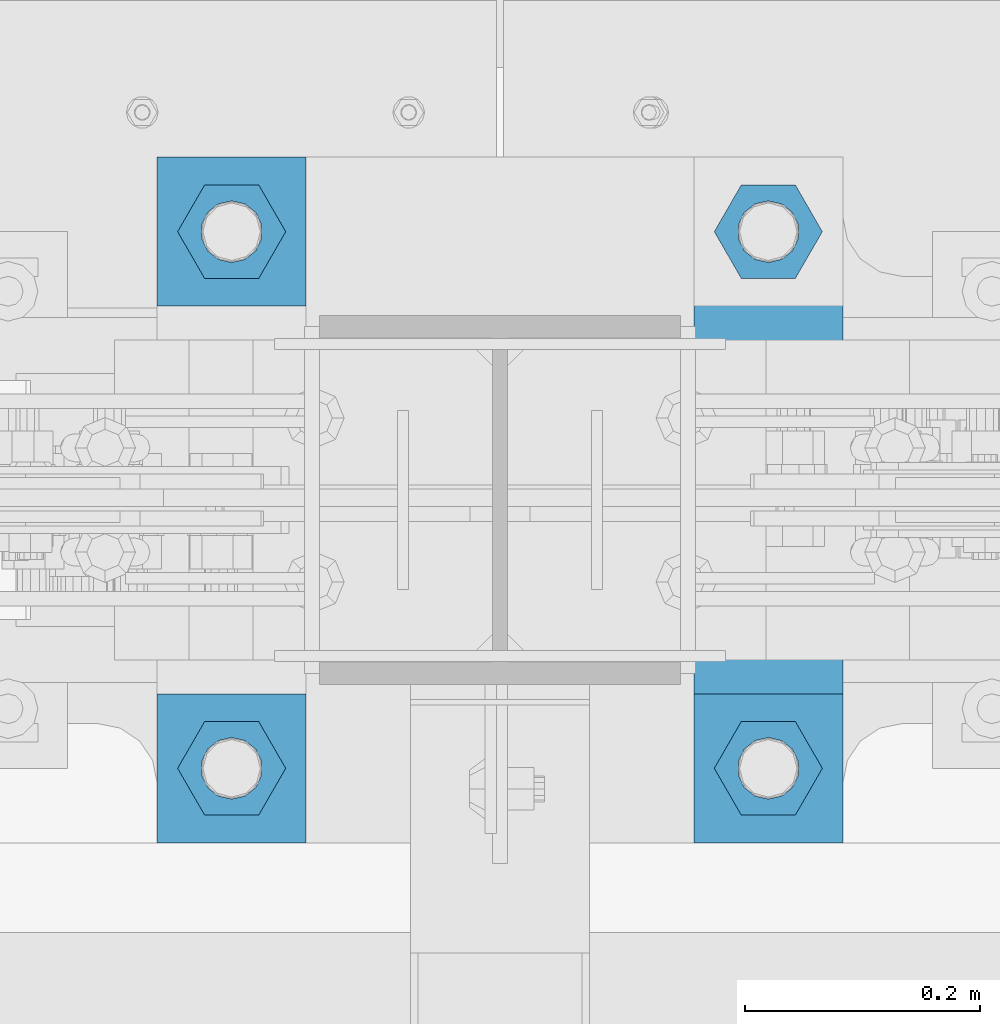
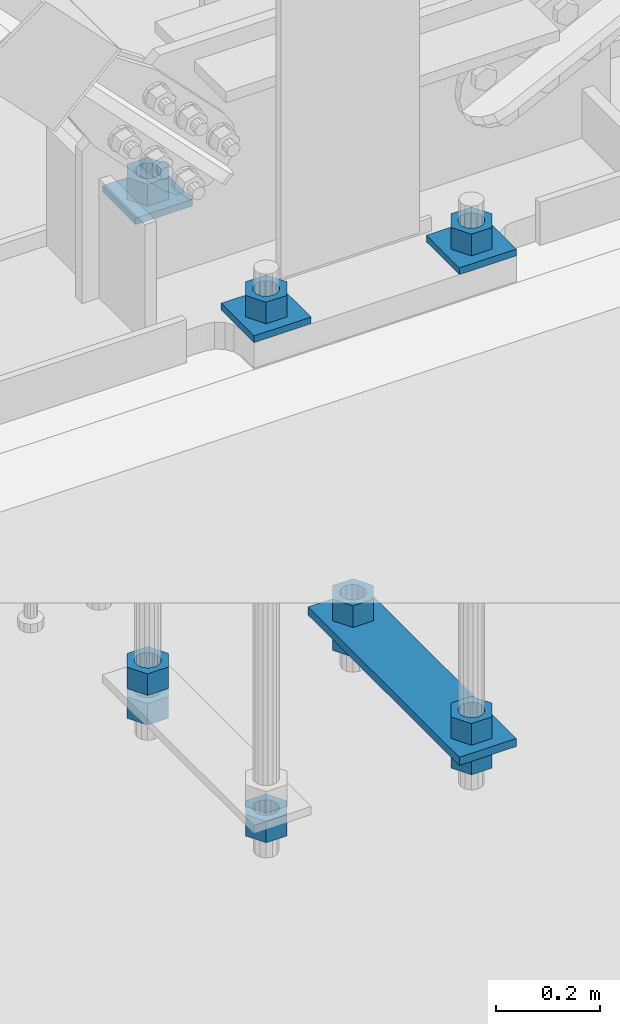
# One storey, part 887 of 1179: 14 beams, 1 element without a shape of its own.
"""IFC2X3 building model written with IfcOpenShell, lengths in millimetres."""

from ifc_helpers import new_model, si_unit, frame, origin_with_axes, place, context, subcontext, project, spatial, faceted_brep, material, type_object, element, aggregate, save


model = new_model("IFC2X3")

# Units and contexts
model_context = context("Model", 3, precision=1e-05, world=origin_with_axes())
body_context = subcontext(model_context, "Body", "Model", "MODEL_VIEW")
ifc_project = project(units=[si_unit("LENGTHUNIT", "METRE", prefix="MILLI"), si_unit("AREAUNIT", "SQUARE_METRE"), si_unit("VOLUMEUNIT", "CUBIC_METRE"), si_unit("MASSUNIT", "GRAM", prefix="KILO"), si_unit("TIMEUNIT", "SECOND"), si_unit("PLANEANGLEUNIT", "RADIAN"), si_unit("SOLIDANGLEUNIT", "STERADIAN"), si_unit("THERMODYNAMICTEMPERATUREUNIT", "DEGREE_CELSIUS"), si_unit("LUMINOUSINTENSITYUNIT", "LUMEN")], contexts=[model_context])

# Site, building, storey
site_placement = place(None, origin_with_axes())
site = spatial("IfcSite", under=ifc_project, at=site_placement, CompositionType="ELEMENT")
building_placement = place(site_placement, origin_with_axes())
building = spatial("IfcBuilding", under=site, at=building_placement, Name="Undefined", CompositionType="ELEMENT")
storey_placement = place(building_placement, origin_with_axes())
storey = spatial("IfcBuildingStorey", under=building, at=storey_placement, Name="Undefined", CompositionType="ELEMENT", Elevation=0.0)

# Assembly, beams
assembly_placement = place(storey_placement, origin_with_axes())
assembly = element("IfcElementAssembly", 1, at=assembly_placement, inside=storey, Name="TEMPLATE", AssemblyPlace="NOTDEFINED", PredefinedType="RIGID_FRAME")
ifc_material = material(Name="STEEL/A36")
beam_type_1 = type_object("IfcBeamType", PredefinedType="NOTDEFINED")
beam_1_placement = place(assembly_placement, frame((8115.30000000002, 41427.4000061035, -207.9625), z_axis=(0.0, -1.0, 0.0), x_axis=(-1.0, 0.0, 0.0)))
beam_1 = element("IfcBeam", 2, at=beam_1_placement, type_object=beam_type_1, material=ifc_material, Name="SQ WASHER", context=body_context, shape_type="Brep", body=[
    faceted_brep([(0.0, 7.9375, -63.5), (0.0, 7.9375, 63.5), (127.0, 7.9375, 63.5), (127.0, 7.9375, -63.5), (0.0, -7.9375, 63.5), (127.0, -7.9375, 63.5), (0.0, -7.9375, -63.5), (127.0, -7.9375, -63.5)], [[[0, 1, 2, 3]], [[1, 4, 5, 2]], [[4, 6, 7, 5]], [[6, 0, 3, 7]], [[5, 7, 3, 2]], [[6, 4, 1, 0]]]),
])
beam_2_placement = place(assembly_placement, frame((8115.30000000002, 40970.2000061035, -207.9625), z_axis=(0.0, -1.0, 0.0), x_axis=(-1.0, 0.0, 0.0)))
beam_2 = element("IfcBeam", 3, at=beam_2_placement, type_object=beam_type_1, material=ifc_material, Name="SQ WASHER", context=body_context, shape_type="Brep", body=[
    faceted_brep([(0.0, 7.9375, -63.5), (0.0, 7.9375, 63.5), (127.0, 7.9375, 63.5), (127.0, 7.9375, -63.5), (0.0, -7.9375, 63.5), (127.0, -7.9375, 63.5), (0.0, -7.9375, -63.5), (127.0, -7.9375, -63.5)], [[[0, 1, 2, 3]], [[1, 4, 5, 2]], [[4, 6, 7, 5]], [[6, 0, 3, 7]], [[5, 7, 3, 2]], [[6, 4, 1, 0]]]),
])
beam_3_placement = place(assembly_placement, frame((8445.5, 40970.1999938965, -207.9625), z_axis=(0.0, 1.0, 0.0), x_axis=(1.0, 0.0, 0.0)))
beam_3 = element("IfcBeam", 4, at=beam_3_placement, type_object=beam_type_1, material=ifc_material, Name="SQ WASHER", context=body_context, shape_type="Brep", body=[
    faceted_brep([(0.0, 7.9375, -63.5), (0.0, 7.9375, 63.5), (127.0, 7.9375, 63.5), (127.0, 7.9375, -63.5), (0.0, -7.9375, 63.5), (127.0, -7.9375, 63.5), (0.0, -7.9375, -63.5), (127.0, -7.9375, -63.5)], [[[0, 1, 2, 3]], [[1, 4, 5, 2]], [[4, 6, 7, 5]], [[6, 0, 3, 7]], [[5, 7, 3, 2]], [[6, 4, 1, 0]]]),
])
beam_type_2 = type_object("IfcBeamType", PredefinedType="NOTDEFINED")
beam_4_placement = place(assembly_placement, frame((8509.00000610352, 40906.7, -1362.075), z_axis=(-1.0, 0.0, 0.0), x_axis=(0.0, 1.0, 0.0)))
beam_4 = element("IfcBeam", 5, at=beam_4_placement, type_object=beam_type_2, material=ifc_material, Name="SQ WASHER", context=body_context, shape_type="Brep", body=[
    faceted_brep([(0.0, 9.52500000000146, -63.5), (0.0, 9.52500000000146, 63.5), (584.199999999997, 9.52500000000009, 63.5), (584.199999999997, 9.52500000000009, -63.5), (0.0, -9.52500000000146, 63.5), (584.199999999997, -9.52500000000009, 63.5), (0.0, -9.52500000000146, -63.5), (584.199999999997, -9.52500000000009, -63.5)], [[[0, 1, 2, 3]], [[1, 4, 5, 2]], [[4, 6, 7, 5]], [[6, 0, 3, 7]], [[5, 7, 3, 2]], [[6, 4, 1, 0]]]),
])
beam_type_3 = type_object("IfcBeamType", Name="2_HEAVY_HEX_NUT", PredefinedType="NOTDEFINED")
beam_5_placement = place(assembly_placement, frame((8051.80000000002, 40970.2, -1371.59999923706), z_axis=(0.0, -1.0, 0.0), x_axis=(0.0, 0.0, -1.0)))
beam_5 = element("IfcBeam", 6, at=beam_5_placement, type_object=beam_type_3, material=ifc_material, Name="NUT", ObjectType="2_HEAVY_HEX_NUT", context=body_context, shape_type="Brep", body=[
    faceted_brep([(0.0, -46.0369987487793, 9.09494701772928e-13), (0.0, -23.0184993743896, -39.869213104248), (50.7999999999993, -23.0184993743896, -39.869213104248), (50.7999999999993, -46.0369987487793, 9.09494701772928e-13), (0.0, 23.0184993743896, -39.869213104248), (50.7999999999993, 23.0184993743896, -39.869213104248), (0.0, 46.0369987487793, -9.09494701772928e-13), (50.7999999999993, 46.0369987487793, -9.09494701772928e-13), (0.0, 23.0184993743896, 39.869213104248), (50.7999999999993, 23.0184993743896, 39.869213104248), (0.0, -23.0184993743896, 39.869213104248), (50.7999999999993, -23.0184993743896, 39.869213104248), (0.0, 0.0, 26.1940002441406), (0.0, 11.3650617044477, 23.5999013092769), (50.7999999999993, 11.3650617044477, 23.5999013092769), (50.7999999999993, 0.0, 26.1940002441406), (0.0, 20.4791109456419, 16.3316083006703), (50.7999999999993, 20.4791109456419, 16.3316083006703), (0.0, 25.5370200498364, 5.82867859874477), (50.7999999999993, 25.5370200498364, 5.82867859874477), (0.0, 25.5370200498364, -5.82867859874477), (50.7999999999993, 25.5370200498364, -5.82867859874477), (0.0, 20.4791109456419, -16.3316083006703), (50.7999999999993, 20.4791109456419, -16.3316083006703), (0.0, 11.365061704455, -23.5999013092769), (50.7999999999993, 11.365061704455, -23.5999013092769), (0.0, 0.0, -26.1940002441406), (50.7999999999993, 0.0, -26.1940002441406), (0.0, -11.3650617044477, -23.5999013092769), (50.7999999999993, -11.3650617044477, -23.5999013092769), (0.0, -20.4791109456419, -16.3316083006703), (50.7999999999993, -20.4791109456419, -16.3316083006703), (0.0, -25.5370200498364, -5.82867859874477), (50.7999999999993, -25.5370200498364, -5.82867859874477), (0.0, -25.5370200498364, 5.82867859874477), (50.7999999999993, -25.5370200498364, 5.82867859874477), (0.0, -20.4791109456419, 16.3316083006703), (50.7999999999993, -20.4791109456419, 16.3316083006703), (0.0, -11.365061704455, 23.5999013092769), (50.7999999999993, -11.365061704455, 23.5999013092769)], [[[0, 1, 2, 3]], [[1, 4, 5, 2]], [[4, 6, 7, 5]], [[6, 8, 9, 7]], [[8, 10, 11, 9]], [[10, 0, 3, 11]], [[12, 13, 14, 15]], [[13, 16, 17, 14]], [[16, 18, 19, 17]], [[18, 20, 21, 19]], [[20, 22, 23, 21]], [[22, 24, 25, 23]], [[24, 26, 27, 25]], [[26, 28, 29, 27]], [[28, 30, 31, 29]], [[30, 32, 33, 31]], [[32, 34, 35, 33]], [[34, 36, 37, 35]], [[36, 38, 39, 37]], [[38, 12, 15, 39]], [[5, 7, 9, 11, 3, 2], [17, 19, 21, 23, 25, 27, 29, 31, 33, 35, 37, 39, 15, 14]], [[10, 8, 6, 4, 1, 0], [38, 36, 34, 32, 30, 28, 26, 24, 22, 20, 18, 16, 13, 12]]]),
])
beam_6_placement = place(assembly_placement, frame((8051.80000000002, 41427.4, -1301.75), z_axis=(0.0, -1.0, 0.0), x_axis=(0.0, 0.0, -1.0)))
beam_6 = element("IfcBeam", 7, at=beam_6_placement, type_object=beam_type_3, material=ifc_material, Name="NUT", ObjectType="2_HEAVY_HEX_NUT", context=body_context, shape_type="Brep", body=[
    faceted_brep([(0.0, -46.0369987487793, 9.09494701772928e-13), (0.0, -23.0184993743896, -39.869213104248), (50.7999999999993, -23.0184993743896, -39.869213104248), (50.7999999999993, -46.0369987487793, 9.09494701772928e-13), (0.0, 23.0184993743896, -39.869213104248), (50.7999999999993, 23.0184993743896, -39.869213104248), (0.0, 46.0369987487793, -9.09494701772928e-13), (50.7999999999993, 46.0369987487793, -9.09494701772928e-13), (0.0, 23.0184993743896, 39.869213104248), (50.7999999999993, 23.0184993743896, 39.869213104248), (0.0, -23.0184993743896, 39.869213104248), (50.7999999999993, -23.0184993743896, 39.869213104248), (0.0, 0.0, 26.1940002441406), (0.0, 11.3650617044477, 23.5999013092769), (50.7999999999993, 11.3650617044477, 23.5999013092769), (50.7999999999993, 0.0, 26.1940002441406), (0.0, 20.4791109456419, 16.3316083006703), (50.7999999999993, 20.4791109456419, 16.3316083006703), (0.0, 25.5370200498364, 5.82867859874477), (50.7999999999993, 25.5370200498364, 5.82867859874477), (0.0, 25.5370200498364, -5.82867859874477), (50.7999999999993, 25.5370200498364, -5.82867859874477), (0.0, 20.4791109456419, -16.3316083006703), (50.7999999999993, 20.4791109456419, -16.3316083006703), (0.0, 11.365061704455, -23.5999013092769), (50.7999999999993, 11.365061704455, -23.5999013092769), (0.0, 0.0, -26.1940002441406), (50.7999999999993, 0.0, -26.1940002441406), (0.0, -11.3650617044477, -23.5999013092769), (50.7999999999993, -11.3650617044477, -23.5999013092769), (0.0, -20.4791109456419, -16.3316083006703), (50.7999999999993, -20.4791109456419, -16.3316083006703), (0.0, -25.5370200498364, -5.82867859874477), (50.7999999999993, -25.5370200498364, -5.82867859874477), (0.0, -25.5370200498364, 5.82867859874477), (50.7999999999993, -25.5370200498364, 5.82867859874477), (0.0, -20.4791109456419, 16.3316083006703), (50.7999999999993, -20.4791109456419, 16.3316083006703), (0.0, -11.365061704455, 23.5999013092769), (50.7999999999993, -11.365061704455, 23.5999013092769)], [[[0, 1, 2, 3]], [[1, 4, 5, 2]], [[4, 6, 7, 5]], [[6, 8, 9, 7]], [[8, 10, 11, 9]], [[10, 0, 3, 11]], [[12, 13, 14, 15]], [[13, 16, 17, 14]], [[16, 18, 19, 17]], [[18, 20, 21, 19]], [[20, 22, 23, 21]], [[22, 24, 25, 23]], [[24, 26, 27, 25]], [[26, 28, 29, 27]], [[28, 30, 31, 29]], [[30, 32, 33, 31]], [[32, 34, 35, 33]], [[34, 36, 37, 35]], [[36, 38, 39, 37]], [[38, 12, 15, 39]], [[5, 7, 9, 11, 3, 2], [17, 19, 21, 23, 25, 27, 29, 31, 33, 35, 37, 39, 15, 14]], [[10, 8, 6, 4, 1, 0], [38, 36, 34, 32, 30, 28, 26, 24, 22, 20, 18, 16, 13, 12]]]),
])
beam_7_placement = place(assembly_placement, frame((8051.80000000002, 41427.400012207, -1371.6), z_axis=(0.0, -1.0, 0.0), x_axis=(0.0, 0.0, -1.0)))
beam_7 = element("IfcBeam", 8, at=beam_7_placement, type_object=beam_type_3, material=ifc_material, Name="NUT", ObjectType="2_HEAVY_HEX_NUT", context=body_context, shape_type="Brep", body=[
    faceted_brep([(0.0, -46.0369987487793, 9.09494701772928e-13), (0.0, -23.0184993743896, -39.869213104248), (50.7999999999993, -23.0184993743896, -39.869213104248), (50.7999999999993, -46.0369987487793, 9.09494701772928e-13), (0.0, 23.0184993743896, -39.869213104248), (50.7999999999993, 23.0184993743896, -39.869213104248), (0.0, 46.0369987487793, -9.09494701772928e-13), (50.7999999999993, 46.0369987487793, -9.09494701772928e-13), (0.0, 23.0184993743896, 39.869213104248), (50.7999999999993, 23.0184993743896, 39.869213104248), (0.0, -23.0184993743896, 39.869213104248), (50.7999999999993, -23.0184993743896, 39.869213104248), (0.0, 0.0, 26.1940002441406), (0.0, 11.3650617044477, 23.5999013092769), (50.7999999999993, 11.3650617044477, 23.5999013092769), (50.7999999999993, 0.0, 26.1940002441406), (0.0, 20.4791109456419, 16.3316083006703), (50.7999999999993, 20.4791109456419, 16.3316083006703), (0.0, 25.5370200498364, 5.82867859874477), (50.7999999999993, 25.5370200498364, 5.82867859874477), (0.0, 25.5370200498364, -5.82867859874477), (50.7999999999993, 25.5370200498364, -5.82867859874477), (0.0, 20.4791109456419, -16.3316083006703), (50.7999999999993, 20.4791109456419, -16.3316083006703), (0.0, 11.365061704455, -23.5999013092769), (50.7999999999993, 11.365061704455, -23.5999013092769), (0.0, 0.0, -26.1940002441406), (50.7999999999993, 0.0, -26.1940002441406), (0.0, -11.3650617044477, -23.5999013092769), (50.7999999999993, -11.3650617044477, -23.5999013092769), (0.0, -20.4791109456419, -16.3316083006703), (50.7999999999993, -20.4791109456419, -16.3316083006703), (0.0, -25.5370200498364, -5.82867859874477), (50.7999999999993, -25.5370200498364, -5.82867859874477), (0.0, -25.5370200498364, 5.82867859874477), (50.7999999999993, -25.5370200498364, 5.82867859874477), (0.0, -20.4791109456419, 16.3316083006703), (50.7999999999993, -20.4791109456419, 16.3316083006703), (0.0, -11.365061704455, 23.5999013092769), (50.7999999999993, -11.365061704455, 23.5999013092769)], [[[0, 1, 2, 3]], [[1, 4, 5, 2]], [[4, 6, 7, 5]], [[6, 8, 9, 7]], [[8, 10, 11, 9]], [[10, 0, 3, 11]], [[12, 13, 14, 15]], [[13, 16, 17, 14]], [[16, 18, 19, 17]], [[18, 20, 21, 19]], [[20, 22, 23, 21]], [[22, 24, 25, 23]], [[24, 26, 27, 25]], [[26, 28, 29, 27]], [[28, 30, 31, 29]], [[30, 32, 33, 31]], [[32, 34, 35, 33]], [[34, 36, 37, 35]], [[36, 38, 39, 37]], [[38, 12, 15, 39]], [[5, 7, 9, 11, 3, 2], [17, 19, 21, 23, 25, 27, 29, 31, 33, 35, 37, 39, 15, 14]], [[10, 8, 6, 4, 1, 0], [38, 36, 34, 32, 30, 28, 26, 24, 22, 20, 18, 16, 13, 12]]]),
])
beam_8_placement = place(assembly_placement, frame((8509.0, 41427.4, -1301.75), z_axis=(0.0, 1.0, 0.0), x_axis=(0.0, 0.0, -1.0)))
beam_8 = element("IfcBeam", 9, at=beam_8_placement, type_object=beam_type_3, material=ifc_material, Name="NUT", ObjectType="2_HEAVY_HEX_NUT", context=body_context, shape_type="Brep", body=[
    faceted_brep([(0.0, -46.0369987487793, 9.09494701772928e-13), (0.0, -23.0184993743896, -39.869213104248), (50.7999999999993, -23.0184993743896, -39.869213104248), (50.7999999999993, -46.0369987487793, 9.09494701772928e-13), (0.0, 23.0184993743896, -39.869213104248), (50.7999999999993, 23.0184993743896, -39.869213104248), (0.0, 46.0369987487793, -9.09494701772928e-13), (50.7999999999993, 46.0369987487793, -9.09494701772928e-13), (0.0, 23.0184993743896, 39.869213104248), (50.7999999999993, 23.0184993743896, 39.869213104248), (0.0, -23.0184993743896, 39.869213104248), (50.7999999999993, -23.0184993743896, 39.869213104248), (0.0, 0.0, 26.1940002441406), (0.0, 11.3650617044477, 23.5999013092769), (50.7999999999993, 11.3650617044477, 23.5999013092769), (50.7999999999993, 0.0, 26.1940002441406), (0.0, 20.4791109456419, 16.3316083006703), (50.7999999999993, 20.4791109456419, 16.3316083006703), (0.0, 25.5370200498364, 5.82867859874477), (50.7999999999993, 25.5370200498364, 5.82867859874477), (0.0, 25.5370200498364, -5.82867859874477), (50.7999999999993, 25.5370200498364, -5.82867859874477), (0.0, 20.4791109456419, -16.3316083006703), (50.7999999999993, 20.4791109456419, -16.3316083006703), (0.0, 11.365061704455, -23.5999013092769), (50.7999999999993, 11.365061704455, -23.5999013092769), (0.0, 0.0, -26.1940002441406), (50.7999999999993, 0.0, -26.1940002441406), (0.0, -11.3650617044477, -23.5999013092769), (50.7999999999993, -11.3650617044477, -23.5999013092769), (0.0, -20.4791109456419, -16.3316083006703), (50.7999999999993, -20.4791109456419, -16.3316083006703), (0.0, -25.5370200498364, -5.82867859874477), (50.7999999999993, -25.5370200498364, -5.82867859874477), (0.0, -25.5370200498364, 5.82867859874477), (50.7999999999993, -25.5370200498364, 5.82867859874477), (0.0, -20.4791109456419, 16.3316083006703), (50.7999999999993, -20.4791109456419, 16.3316083006703), (0.0, -11.365061704455, 23.5999013092769), (50.7999999999993, -11.365061704455, 23.5999013092769)], [[[0, 1, 2, 3]], [[1, 4, 5, 2]], [[4, 6, 7, 5]], [[6, 8, 9, 7]], [[8, 10, 11, 9]], [[10, 0, 3, 11]], [[12, 13, 14, 15]], [[13, 16, 17, 14]], [[16, 18, 19, 17]], [[18, 20, 21, 19]], [[20, 22, 23, 21]], [[22, 24, 25, 23]], [[24, 26, 27, 25]], [[26, 28, 29, 27]], [[28, 30, 31, 29]], [[30, 32, 33, 31]], [[32, 34, 35, 33]], [[34, 36, 37, 35]], [[36, 38, 39, 37]], [[38, 12, 15, 39]], [[5, 7, 9, 11, 3, 2], [17, 19, 21, 23, 25, 27, 29, 31, 33, 35, 37, 39, 15, 14]], [[10, 8, 6, 4, 1, 0], [38, 36, 34, 32, 30, 28, 26, 24, 22, 20, 18, 16, 13, 12]]]),
])
beam_9_placement = place(assembly_placement, frame((8509.0, 41427.4, -1371.59999923706), z_axis=(0.0, 1.0, 0.0), x_axis=(0.0, 0.0, -1.0)))
beam_9 = element("IfcBeam", 10, at=beam_9_placement, type_object=beam_type_3, material=ifc_material, Name="NUT", ObjectType="2_HEAVY_HEX_NUT", context=body_context, shape_type="Brep", body=[
    faceted_brep([(0.0, -46.0369987487793, 9.09494701772928e-13), (0.0, -23.0184993743896, -39.869213104248), (50.7999999999993, -23.0184993743896, -39.869213104248), (50.7999999999993, -46.0369987487793, 9.09494701772928e-13), (0.0, 23.0184993743896, -39.869213104248), (50.7999999999993, 23.0184993743896, -39.869213104248), (0.0, 46.0369987487793, -9.09494701772928e-13), (50.7999999999993, 46.0369987487793, -9.09494701772928e-13), (0.0, 23.0184993743896, 39.869213104248), (50.7999999999993, 23.0184993743896, 39.869213104248), (0.0, -23.0184993743896, 39.869213104248), (50.7999999999993, -23.0184993743896, 39.869213104248), (0.0, 0.0, 26.1940002441406), (0.0, 11.3650617044477, 23.5999013092769), (50.7999999999993, 11.3650617044477, 23.5999013092769), (50.7999999999993, 0.0, 26.1940002441406), (0.0, 20.4791109456419, 16.3316083006703), (50.7999999999993, 20.4791109456419, 16.3316083006703), (0.0, 25.5370200498364, 5.82867859874477), (50.7999999999993, 25.5370200498364, 5.82867859874477), (0.0, 25.5370200498364, -5.82867859874477), (50.7999999999993, 25.5370200498364, -5.82867859874477), (0.0, 20.4791109456419, -16.3316083006703), (50.7999999999993, 20.4791109456419, -16.3316083006703), (0.0, 11.365061704455, -23.5999013092769), (50.7999999999993, 11.365061704455, -23.5999013092769), (0.0, 0.0, -26.1940002441406), (50.7999999999993, 0.0, -26.1940002441406), (0.0, -11.3650617044477, -23.5999013092769), (50.7999999999993, -11.3650617044477, -23.5999013092769), (0.0, -20.4791109456419, -16.3316083006703), (50.7999999999993, -20.4791109456419, -16.3316083006703), (0.0, -25.5370200498364, -5.82867859874477), (50.7999999999993, -25.5370200498364, -5.82867859874477), (0.0, -25.5370200498364, 5.82867859874477), (50.7999999999993, -25.5370200498364, 5.82867859874477), (0.0, -20.4791109456419, 16.3316083006703), (50.7999999999993, -20.4791109456419, 16.3316083006703), (0.0, -11.365061704455, 23.5999013092769), (50.7999999999993, -11.365061704455, 23.5999013092769)], [[[0, 1, 2, 3]], [[1, 4, 5, 2]], [[4, 6, 7, 5]], [[6, 8, 9, 7]], [[8, 10, 11, 9]], [[10, 0, 3, 11]], [[12, 13, 14, 15]], [[13, 16, 17, 14]], [[16, 18, 19, 17]], [[18, 20, 21, 19]], [[20, 22, 23, 21]], [[22, 24, 25, 23]], [[24, 26, 27, 25]], [[26, 28, 29, 27]], [[28, 30, 31, 29]], [[30, 32, 33, 31]], [[32, 34, 35, 33]], [[34, 36, 37, 35]], [[36, 38, 39, 37]], [[38, 12, 15, 39]], [[5, 7, 9, 11, 3, 2], [17, 19, 21, 23, 25, 27, 29, 31, 33, 35, 37, 39, 15, 14]], [[10, 8, 6, 4, 1, 0], [38, 36, 34, 32, 30, 28, 26, 24, 22, 20, 18, 16, 13, 12]]]),
])
beam_10_placement = place(assembly_placement, frame((8509.0, 40970.2, -1301.75), z_axis=(0.0, 1.0, 0.0), x_axis=(0.0, 0.0, -1.0)))
beam_10 = element("IfcBeam", 11, at=beam_10_placement, type_object=beam_type_3, material=ifc_material, Name="NUT", ObjectType="2_HEAVY_HEX_NUT", context=body_context, shape_type="Brep", body=[
    faceted_brep([(0.0, -46.0369987487793, 9.09494701772928e-13), (0.0, -23.0184993743896, -39.869213104248), (50.7999999999993, -23.0184993743896, -39.869213104248), (50.7999999999993, -46.0369987487793, 9.09494701772928e-13), (0.0, 23.0184993743896, -39.869213104248), (50.7999999999993, 23.0184993743896, -39.869213104248), (0.0, 46.0369987487793, -9.09494701772928e-13), (50.7999999999993, 46.0369987487793, -9.09494701772928e-13), (0.0, 23.0184993743896, 39.869213104248), (50.7999999999993, 23.0184993743896, 39.869213104248), (0.0, -23.0184993743896, 39.869213104248), (50.7999999999993, -23.0184993743896, 39.869213104248), (0.0, 0.0, 26.1940002441406), (0.0, 11.3650617044477, 23.5999013092769), (50.7999999999993, 11.3650617044477, 23.5999013092769), (50.7999999999993, 0.0, 26.1940002441406), (0.0, 20.4791109456419, 16.3316083006703), (50.7999999999993, 20.4791109456419, 16.3316083006703), (0.0, 25.5370200498364, 5.82867859874477), (50.7999999999993, 25.5370200498364, 5.82867859874477), (0.0, 25.5370200498364, -5.82867859874477), (50.7999999999993, 25.5370200498364, -5.82867859874477), (0.0, 20.4791109456419, -16.3316083006703), (50.7999999999993, 20.4791109456419, -16.3316083006703), (0.0, 11.365061704455, -23.5999013092769), (50.7999999999993, 11.365061704455, -23.5999013092769), (0.0, 0.0, -26.1940002441406), (50.7999999999993, 0.0, -26.1940002441406), (0.0, -11.3650617044477, -23.5999013092769), (50.7999999999993, -11.3650617044477, -23.5999013092769), (0.0, -20.4791109456419, -16.3316083006703), (50.7999999999993, -20.4791109456419, -16.3316083006703), (0.0, -25.5370200498364, -5.82867859874477), (50.7999999999993, -25.5370200498364, -5.82867859874477), (0.0, -25.5370200498364, 5.82867859874477), (50.7999999999993, -25.5370200498364, 5.82867859874477), (0.0, -20.4791109456419, 16.3316083006703), (50.7999999999993, -20.4791109456419, 16.3316083006703), (0.0, -11.365061704455, 23.5999013092769), (50.7999999999993, -11.365061704455, 23.5999013092769)], [[[0, 1, 2, 3]], [[1, 4, 5, 2]], [[4, 6, 7, 5]], [[6, 8, 9, 7]], [[8, 10, 11, 9]], [[10, 0, 3, 11]], [[12, 13, 14, 15]], [[13, 16, 17, 14]], [[16, 18, 19, 17]], [[18, 20, 21, 19]], [[20, 22, 23, 21]], [[22, 24, 25, 23]], [[24, 26, 27, 25]], [[26, 28, 29, 27]], [[28, 30, 31, 29]], [[30, 32, 33, 31]], [[32, 34, 35, 33]], [[34, 36, 37, 35]], [[36, 38, 39, 37]], [[38, 12, 15, 39]], [[5, 7, 9, 11, 3, 2], [17, 19, 21, 23, 25, 27, 29, 31, 33, 35, 37, 39, 15, 14]], [[10, 8, 6, 4, 1, 0], [38, 36, 34, 32, 30, 28, 26, 24, 22, 20, 18, 16, 13, 12]]]),
])
beam_11_placement = place(assembly_placement, frame((8509.0, 40970.1999938965, -1371.6), z_axis=(0.0, 1.0, 0.0), x_axis=(0.0, 0.0, -1.0)))
beam_11 = element("IfcBeam", 12, at=beam_11_placement, type_object=beam_type_3, material=ifc_material, Name="NUT", ObjectType="2_HEAVY_HEX_NUT", context=body_context, shape_type="Brep", body=[
    faceted_brep([(0.0, -46.0369987487793, 9.09494701772928e-13), (0.0, -23.0184993743896, -39.869213104248), (50.7999999999993, -23.0184993743896, -39.869213104248), (50.7999999999993, -46.0369987487793, 9.09494701772928e-13), (0.0, 23.0184993743896, -39.869213104248), (50.7999999999993, 23.0184993743896, -39.869213104248), (0.0, 46.0369987487793, -9.09494701772928e-13), (50.7999999999993, 46.0369987487793, -9.09494701772928e-13), (0.0, 23.0184993743896, 39.869213104248), (50.7999999999993, 23.0184993743896, 39.869213104248), (0.0, -23.0184993743896, 39.869213104248), (50.7999999999993, -23.0184993743896, 39.869213104248), (0.0, 0.0, 26.1940002441406), (0.0, 11.3650617044477, 23.5999013092769), (50.7999999999993, 11.3650617044477, 23.5999013092769), (50.7999999999993, 0.0, 26.1940002441406), (0.0, 20.4791109456419, 16.3316083006703), (50.7999999999993, 20.4791109456419, 16.3316083006703), (0.0, 25.5370200498364, 5.82867859874477), (50.7999999999993, 25.5370200498364, 5.82867859874477), (0.0, 25.5370200498364, -5.82867859874477), (50.7999999999993, 25.5370200498364, -5.82867859874477), (0.0, 20.4791109456419, -16.3316083006703), (50.7999999999993, 20.4791109456419, -16.3316083006703), (0.0, 11.365061704455, -23.5999013092769), (50.7999999999993, 11.365061704455, -23.5999013092769), (0.0, 0.0, -26.1940002441406), (50.7999999999993, 0.0, -26.1940002441406), (0.0, -11.3650617044477, -23.5999013092769), (50.7999999999993, -11.3650617044477, -23.5999013092769), (0.0, -20.4791109456419, -16.3316083006703), (50.7999999999993, -20.4791109456419, -16.3316083006703), (0.0, -25.5370200498364, -5.82867859874477), (50.7999999999993, -25.5370200498364, -5.82867859874477), (0.0, -25.5370200498364, 5.82867859874477), (50.7999999999993, -25.5370200498364, 5.82867859874477), (0.0, -20.4791109456419, 16.3316083006703), (50.7999999999993, -20.4791109456419, 16.3316083006703), (0.0, -11.365061704455, 23.5999013092769), (50.7999999999993, -11.365061704455, 23.5999013092769)], [[[0, 1, 2, 3]], [[1, 4, 5, 2]], [[4, 6, 7, 5]], [[6, 8, 9, 7]], [[8, 10, 11, 9]], [[10, 0, 3, 11]], [[12, 13, 14, 15]], [[13, 16, 17, 14]], [[16, 18, 19, 17]], [[18, 20, 21, 19]], [[20, 22, 23, 21]], [[22, 24, 25, 23]], [[24, 26, 27, 25]], [[26, 28, 29, 27]], [[28, 30, 31, 29]], [[30, 32, 33, 31]], [[32, 34, 35, 33]], [[34, 36, 37, 35]], [[36, 38, 39, 37]], [[38, 12, 15, 39]], [[5, 7, 9, 11, 3, 2], [17, 19, 21, 23, 25, 27, 29, 31, 33, 35, 37, 39, 15, 14]], [[10, 8, 6, 4, 1, 0], [38, 36, 34, 32, 30, 28, 26, 24, 22, 20, 18, 16, 13, 12]]]),
])
beam_12_placement = place(assembly_placement, frame((8051.8, 40970.2, -149.225), z_axis=(0.0, -1.0, 0.0), x_axis=(0.0, 0.0, -1.0)))
beam_12 = element("IfcBeam", 13, at=beam_12_placement, type_object=beam_type_3, material=ifc_material, Name="NUT", ObjectType="2_HEAVY_HEX_NUT", context=body_context, shape_type="Brep", body=[
    faceted_brep([(0.0, -46.0369987487793, 9.09494701772928e-13), (0.0, -23.0184993743896, -39.869213104248), (50.7999999999993, -23.0184993743896, -39.869213104248), (50.7999999999993, -46.0369987487793, 9.09494701772928e-13), (0.0, 23.0184993743896, -39.869213104248), (50.7999999999993, 23.0184993743896, -39.869213104248), (0.0, 46.0369987487793, -9.09494701772928e-13), (50.7999999999993, 46.0369987487793, -9.09494701772928e-13), (0.0, 23.0184993743896, 39.869213104248), (50.7999999999993, 23.0184993743896, 39.869213104248), (0.0, -23.0184993743896, 39.869213104248), (50.7999999999993, -23.0184993743896, 39.869213104248), (0.0, 0.0, 26.1940002441406), (0.0, 11.3650617044477, 23.5999013092769), (50.7999999999993, 11.3650617044477, 23.5999013092769), (50.7999999999993, 0.0, 26.1940002441406), (0.0, 20.4791109456419, 16.3316083006703), (50.7999999999993, 20.4791109456419, 16.3316083006703), (0.0, 25.5370200498364, 5.82867859874477), (50.7999999999993, 25.5370200498364, 5.82867859874477), (0.0, 25.5370200498364, -5.82867859874477), (50.7999999999993, 25.5370200498364, -5.82867859874477), (0.0, 20.4791109456419, -16.3316083006703), (50.7999999999993, 20.4791109456419, -16.3316083006703), (0.0, 11.365061704455, -23.5999013092769), (50.7999999999993, 11.365061704455, -23.5999013092769), (0.0, 0.0, -26.1940002441406), (50.7999999999993, 0.0, -26.1940002441406), (0.0, -11.3650617044477, -23.5999013092769), (50.7999999999993, -11.3650617044477, -23.5999013092769), (0.0, -20.4791109456419, -16.3316083006703), (50.7999999999993, -20.4791109456419, -16.3316083006703), (0.0, -25.5370200498364, -5.82867859874477), (50.7999999999993, -25.5370200498364, -5.82867859874477), (0.0, -25.5370200498364, 5.82867859874477), (50.7999999999993, -25.5370200498364, 5.82867859874477), (0.0, -20.4791109456419, 16.3316083006703), (50.7999999999993, -20.4791109456419, 16.3316083006703), (0.0, -11.365061704455, 23.5999013092769), (50.7999999999993, -11.365061704455, 23.5999013092769)], [[[0, 1, 2, 3]], [[1, 4, 5, 2]], [[4, 6, 7, 5]], [[6, 8, 9, 7]], [[8, 10, 11, 9]], [[10, 0, 3, 11]], [[12, 13, 14, 15]], [[13, 16, 17, 14]], [[16, 18, 19, 17]], [[18, 20, 21, 19]], [[20, 22, 23, 21]], [[22, 24, 25, 23]], [[24, 26, 27, 25]], [[26, 28, 29, 27]], [[28, 30, 31, 29]], [[30, 32, 33, 31]], [[32, 34, 35, 33]], [[34, 36, 37, 35]], [[36, 38, 39, 37]], [[38, 12, 15, 39]], [[5, 7, 9, 11, 3, 2], [17, 19, 21, 23, 25, 27, 29, 31, 33, 35, 37, 39, 15, 14]], [[10, 8, 6, 4, 1, 0], [38, 36, 34, 32, 30, 28, 26, 24, 22, 20, 18, 16, 13, 12]]]),
])
beam_13_placement = place(assembly_placement, frame((8509.00000000001, 40970.2, -149.225), z_axis=(0.0, 1.0, 0.0), x_axis=(0.0, 0.0, -1.0)))
beam_13 = element("IfcBeam", 14, at=beam_13_placement, type_object=beam_type_3, material=ifc_material, Name="NUT", ObjectType="2_HEAVY_HEX_NUT", context=body_context, shape_type="Brep", body=[
    faceted_brep([(0.0, -46.0369987487793, 9.09494701772928e-13), (0.0, -23.0184993743896, -39.869213104248), (50.7999999999993, -23.0184993743896, -39.869213104248), (50.7999999999993, -46.0369987487793, 9.09494701772928e-13), (0.0, 23.0184993743896, -39.869213104248), (50.7999999999993, 23.0184993743896, -39.869213104248), (0.0, 46.0369987487793, -9.09494701772928e-13), (50.7999999999993, 46.0369987487793, -9.09494701772928e-13), (0.0, 23.0184993743896, 39.869213104248), (50.7999999999993, 23.0184993743896, 39.869213104248), (0.0, -23.0184993743896, 39.869213104248), (50.7999999999993, -23.0184993743896, 39.869213104248), (0.0, 0.0, 26.1940002441406), (0.0, 11.3650617044477, 23.5999013092769), (50.7999999999993, 11.3650617044477, 23.5999013092769), (50.7999999999993, 0.0, 26.1940002441406), (0.0, 20.4791109456419, 16.3316083006703), (50.7999999999993, 20.4791109456419, 16.3316083006703), (0.0, 25.5370200498364, 5.82867859874477), (50.7999999999993, 25.5370200498364, 5.82867859874477), (0.0, 25.5370200498364, -5.82867859874477), (50.7999999999993, 25.5370200498364, -5.82867859874477), (0.0, 20.4791109456419, -16.3316083006703), (50.7999999999993, 20.4791109456419, -16.3316083006703), (0.0, 11.365061704455, -23.5999013092769), (50.7999999999993, 11.365061704455, -23.5999013092769), (0.0, 0.0, -26.1940002441406), (50.7999999999993, 0.0, -26.1940002441406), (0.0, -11.3650617044477, -23.5999013092769), (50.7999999999993, -11.3650617044477, -23.5999013092769), (0.0, -20.4791109456419, -16.3316083006703), (50.7999999999993, -20.4791109456419, -16.3316083006703), (0.0, -25.5370200498364, -5.82867859874477), (50.7999999999993, -25.5370200498364, -5.82867859874477), (0.0, -25.5370200498364, 5.82867859874477), (50.7999999999993, -25.5370200498364, 5.82867859874477), (0.0, -20.4791109456419, 16.3316083006703), (50.7999999999993, -20.4791109456419, 16.3316083006703), (0.0, -11.365061704455, 23.5999013092769), (50.7999999999993, -11.365061704455, 23.5999013092769)], [[[0, 1, 2, 3]], [[1, 4, 5, 2]], [[4, 6, 7, 5]], [[6, 8, 9, 7]], [[8, 10, 11, 9]], [[10, 0, 3, 11]], [[12, 13, 14, 15]], [[13, 16, 17, 14]], [[16, 18, 19, 17]], [[18, 20, 21, 19]], [[20, 22, 23, 21]], [[22, 24, 25, 23]], [[24, 26, 27, 25]], [[26, 28, 29, 27]], [[28, 30, 31, 29]], [[30, 32, 33, 31]], [[32, 34, 35, 33]], [[34, 36, 37, 35]], [[36, 38, 39, 37]], [[38, 12, 15, 39]], [[5, 7, 9, 11, 3, 2], [17, 19, 21, 23, 25, 27, 29, 31, 33, 35, 37, 39, 15, 14]], [[10, 8, 6, 4, 1, 0], [38, 36, 34, 32, 30, 28, 26, 24, 22, 20, 18, 16, 13, 12]]]),
])
beam_14_placement = place(assembly_placement, frame((8051.8, 41427.4, -149.225), z_axis=(0.0, -1.0, 0.0), x_axis=(0.0, 0.0, -1.0)))
beam_14 = element("IfcBeam", 15, at=beam_14_placement, type_object=beam_type_3, material=ifc_material, Name="NUT", ObjectType="2_HEAVY_HEX_NUT", context=body_context, shape_type="Brep", body=[
    faceted_brep([(0.0, -46.0369987487793, 9.09494701772928e-13), (0.0, -23.0184993743896, -39.869213104248), (50.7999999999993, -23.0184993743896, -39.869213104248), (50.7999999999993, -46.0369987487793, 9.09494701772928e-13), (0.0, 23.0184993743896, -39.869213104248), (50.7999999999993, 23.0184993743896, -39.869213104248), (0.0, 46.0369987487793, -9.09494701772928e-13), (50.7999999999993, 46.0369987487793, -9.09494701772928e-13), (0.0, 23.0184993743896, 39.869213104248), (50.7999999999993, 23.0184993743896, 39.869213104248), (0.0, -23.0184993743896, 39.869213104248), (50.7999999999993, -23.0184993743896, 39.869213104248), (0.0, 0.0, 26.1940002441406), (0.0, 11.3650617044477, 23.5999013092769), (50.7999999999993, 11.3650617044477, 23.5999013092769), (50.7999999999993, 0.0, 26.1940002441406), (0.0, 20.4791109456419, 16.3316083006703), (50.7999999999993, 20.4791109456419, 16.3316083006703), (0.0, 25.5370200498364, 5.82867859874477), (50.7999999999993, 25.5370200498364, 5.82867859874477), (0.0, 25.5370200498364, -5.82867859874477), (50.7999999999993, 25.5370200498364, -5.82867859874477), (0.0, 20.4791109456419, -16.3316083006703), (50.7999999999993, 20.4791109456419, -16.3316083006703), (0.0, 11.365061704455, -23.5999013092769), (50.7999999999993, 11.365061704455, -23.5999013092769), (0.0, 0.0, -26.1940002441406), (50.7999999999993, 0.0, -26.1940002441406), (0.0, -11.3650617044477, -23.5999013092769), (50.7999999999993, -11.3650617044477, -23.5999013092769), (0.0, -20.4791109456419, -16.3316083006703), (50.7999999999993, -20.4791109456419, -16.3316083006703), (0.0, -25.5370200498364, -5.82867859874477), (50.7999999999993, -25.5370200498364, -5.82867859874477), (0.0, -25.5370200498364, 5.82867859874477), (50.7999999999993, -25.5370200498364, 5.82867859874477), (0.0, -20.4791109456419, 16.3316083006703), (50.7999999999993, -20.4791109456419, 16.3316083006703), (0.0, -11.365061704455, 23.5999013092769), (50.7999999999993, -11.365061704455, 23.5999013092769)], [[[0, 1, 2, 3]], [[1, 4, 5, 2]], [[4, 6, 7, 5]], [[6, 8, 9, 7]], [[8, 10, 11, 9]], [[10, 0, 3, 11]], [[12, 13, 14, 15]], [[13, 16, 17, 14]], [[16, 18, 19, 17]], [[18, 20, 21, 19]], [[20, 22, 23, 21]], [[22, 24, 25, 23]], [[24, 26, 27, 25]], [[26, 28, 29, 27]], [[28, 30, 31, 29]], [[30, 32, 33, 31]], [[32, 34, 35, 33]], [[34, 36, 37, 35]], [[36, 38, 39, 37]], [[38, 12, 15, 39]], [[5, 7, 9, 11, 3, 2], [17, 19, 21, 23, 25, 27, 29, 31, 33, 35, 37, 39, 15, 14]], [[10, 8, 6, 4, 1, 0], [38, 36, 34, 32, 30, 28, 26, 24, 22, 20, 18, 16, 13, 12]]]),
])
aggregate(assembly, [beam_5, beam_6, beam_7, beam_8, beam_9, beam_10, beam_11, beam_1, beam_2, beam_4, beam_3, beam_12, beam_13, beam_14])

save(model, "model.ifc")
